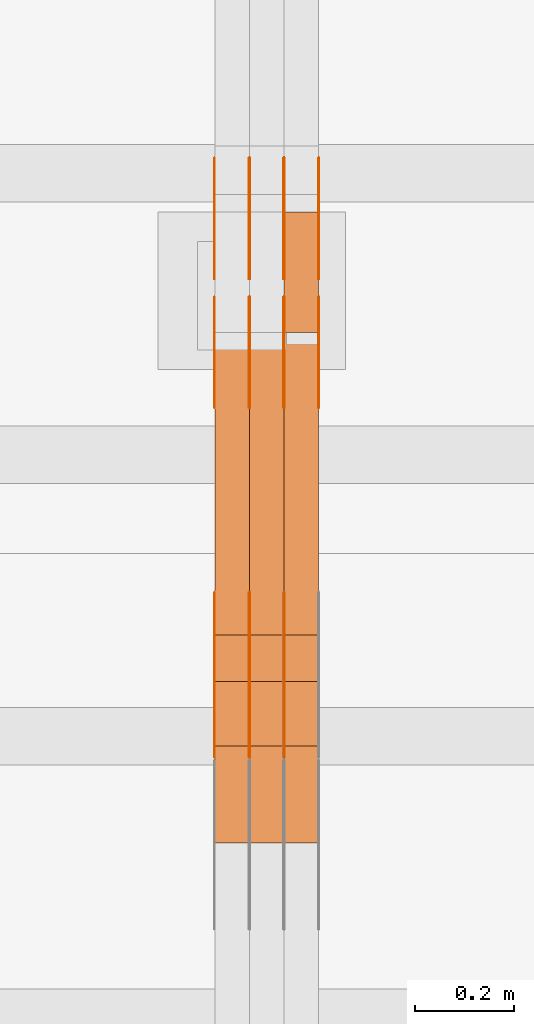
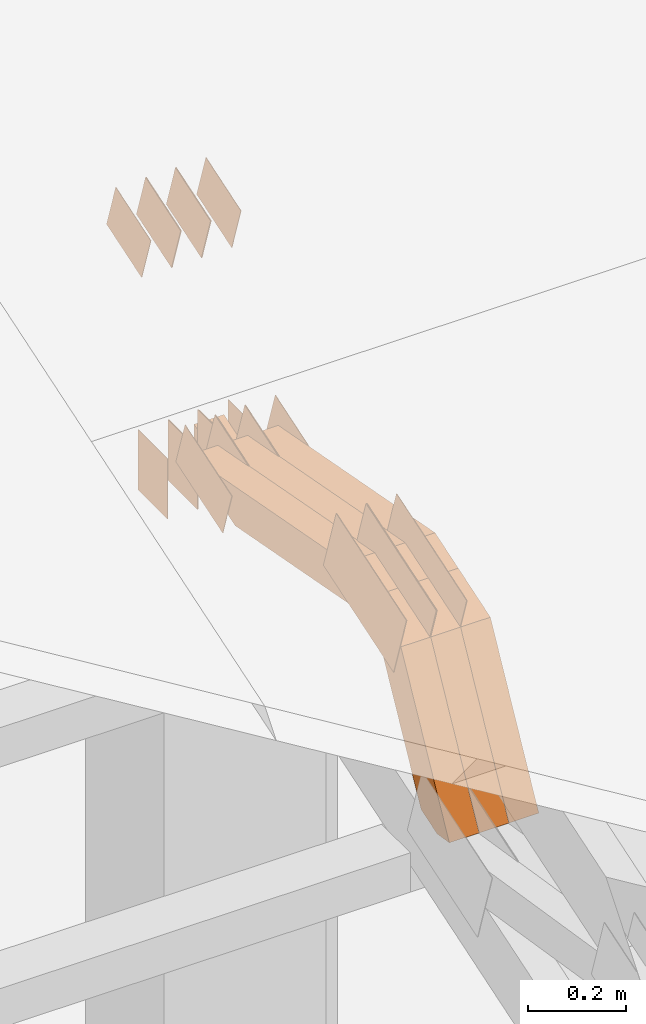
# One storey, part 280 of 385: 29 proxies.
"""IFC2X3 building model written with IfcOpenShell, lengths in millimetres."""

from ifc_helpers import new_model, entity, si_unit, converted_unit, derived_unit, direction, frame, frame_2d, origin, place, context, subcontext, project, spatial, polyline, rectangle, outline, extrude, source, transform, mapped, material, type_object, type_shapes, element, save


model = new_model("IFC2X3")

# Units and contexts
model_context = context("Model", 3, precision=0.01, world=origin(), true_north=direction((6.12303176911189e-17, 1.0)))
body_context = subcontext(model_context, "Body", "Model", "MODEL_VIEW")
ifc_project = project(units=[si_unit("LENGTHUNIT", "METRE", prefix="MILLI"), si_unit("AREAUNIT", "SQUARE_METRE"), si_unit("VOLUMEUNIT", "CUBIC_METRE"), converted_unit("PLANEANGLEUNIT", "DEGREE", entity("IfcRatioMeasure", 0.0174532925199433), si_unit("PLANEANGLEUNIT", "RADIAN"), dimensions=[0, 0, 0, 0, 0, 0, 0]), si_unit("MASSUNIT", "GRAM", prefix="KILO"), derived_unit("MASSDENSITYUNIT", [(si_unit("MASSUNIT", "GRAM", prefix="KILO"), 1), (si_unit("LENGTHUNIT", "METRE"), -3)]), si_unit("TIMEUNIT", "SECOND"), si_unit("FREQUENCYUNIT", "HERTZ"), si_unit("THERMODYNAMICTEMPERATUREUNIT", "DEGREE_CELSIUS"), derived_unit("THERMALTRANSMITTANCEUNIT", [(si_unit("MASSUNIT", "GRAM", prefix="KILO"), 1), (si_unit("THERMODYNAMICTEMPERATUREUNIT", "KELVIN"), -1), (si_unit("TIMEUNIT", "SECOND"), -3)]), derived_unit("VOLUMETRICFLOWRATEUNIT", [(si_unit("LENGTHUNIT", "METRE"), 3), (si_unit("TIMEUNIT", "SECOND"), -1)]), si_unit("ELECTRICCURRENTUNIT", "AMPERE"), si_unit("ELECTRICVOLTAGEUNIT", "VOLT"), si_unit("POWERUNIT", "WATT"), si_unit("FORCEUNIT", "NEWTON", prefix="KILO"), si_unit("ILLUMINANCEUNIT", "LUX"), si_unit("LUMINOUSFLUXUNIT", "LUMEN"), si_unit("LUMINOUSINTENSITYUNIT", "CANDELA"), derived_unit("USERDEFINED", [(si_unit("MASSUNIT", "GRAM", prefix="KILO"), -1), (si_unit("LENGTHUNIT", "METRE"), -2), (si_unit("TIMEUNIT", "SECOND"), 3), (si_unit("LUMINOUSFLUXUNIT", "LUMEN"), 1)]), derived_unit("LINEARVELOCITYUNIT", [(si_unit("LENGTHUNIT", "METRE"), 1), (si_unit("TIMEUNIT", "SECOND"), -1)]), si_unit("PRESSUREUNIT", "PASCAL"), derived_unit("USERDEFINED", [(si_unit("LENGTHUNIT", "METRE"), -2), (si_unit("MASSUNIT", "GRAM", prefix="KILO"), 1), (si_unit("TIMEUNIT", "SECOND"), -2)])], contexts=[model_context])

# Site, building, storey
site_placement = place(None, origin())
site = spatial("IfcSite", under=ifc_project, at=site_placement, CompositionType="ELEMENT")
building_placement = place(site_placement, origin())
building = spatial("IfcBuilding", under=site, at=building_placement, CompositionType="ELEMENT")
storey_placement = place(building_placement, origin())
storey = spatial("IfcBuildingStorey", under=building, at=storey_placement, Name="Default", CompositionType="ELEMENT", Elevation=0.0)

# Proxies
ifc_material_1 = material(Name="IfcSurfaceStyle #448112")
building_element_proxy_type_1 = type_object("IfcBuildingElementProxyType", PredefinedType="NOTDEFINED", material=ifc_material_1)
shared_shape_1 = source(origin(), body_context, "Body", "SweptSolid", [
    extrude(outline(polyline([(-99.9997874178038, -60.0000528641967), (99.9998102700997, -60.0000528641967), (99.9998251396068, 60.0000528641967), (-99.9998479919027, 60.0000528641967), (-99.9997874178038, -60.0000528641967)])), frame((99.9999918898597, 60.0000528641967, 0.0), z_axis=(0.0, 0.0, 1.0), x_axis=(-1.0, 0.0, 0.0)), (0.0, 0.0, 1.0), 1.3),
])
type_shapes(building_element_proxy_type_1, [shared_shape_1])
proxy_1_placement = place(building_placement, frame((36386.3, 11991.9568177725, 3072.52282247925), z_axis=(-1.0, 0.0, 0.0), x_axis=(0.0, 0.951056516295124, 0.309016994375039)))
element("IfcBuildingElementProxy", 1, at=proxy_1_placement, inside=storey, type_object=building_element_proxy_type_1, material=ifc_material_1, context=body_context, shape_type="MappedRepresentation", body=[
    mapped(shared_shape_1, transform((0.0, 0.0, 0.0), scale=1.0)),
])
ifc_material_2 = material(Name="IfcSurfaceStyle #448055")
building_element_proxy_type_2 = type_object("IfcBuildingElementProxyType", PredefinedType="NOTDEFINED", material=ifc_material_2)
shared_shape_2 = source(origin(), body_context, "Body", "SweptSolid", [
    extrude(outline(polyline([(-99.9997874178038, -60.0000528641967), (99.9998102700997, -60.0000528641967), (99.9998251396068, 60.0000528641967), (-99.9998479919027, 60.0000528641967), (-99.9997874178038, -60.0000528641967)])), frame((99.9999918898597, 60.0000528641967, 0.0), z_axis=(0.0, 0.0, 1.0), x_axis=(-1.0, 0.0, 0.0)), (0.0, 0.0, 1.0), 1.3),
])
type_shapes(building_element_proxy_type_2, [shared_shape_2])
proxy_2_placement = place(building_placement, frame((36315.0, 11991.9568177725, 3072.52282247925), z_axis=(-1.0, 0.0, 0.0), x_axis=(0.0, 0.951056516295124, 0.309016994375039)))
element("IfcBuildingElementProxy", 2, at=proxy_2_placement, inside=storey, type_object=building_element_proxy_type_2, material=ifc_material_2, context=body_context, shape_type="MappedRepresentation", body=[
    mapped(shared_shape_2, transform((0.0, 0.0, 0.0), scale=1.0)),
])
ifc_material_3 = material(Name="IfcSurfaceStyle #447998")
building_element_proxy_type_3 = type_object("IfcBuildingElementProxyType", PredefinedType="NOTDEFINED", material=ifc_material_3)
shared_shape_3 = source(origin(), body_context, "Body", "SweptSolid", [
    extrude(outline(polyline([(-99.9997874178038, -60.0000528641967), (99.9998102700997, -60.0000528641967), (99.9998251396068, 60.0000528641967), (-99.9998479919027, 60.0000528641967), (-99.9997874178038, -60.0000528641967)])), frame((99.9999918898597, 60.0000528641967, 0.0), z_axis=(0.0, 0.0, 1.0), x_axis=(-1.0, 0.0, 0.0)), (0.0, 0.0, 1.0), 1.3),
])
type_shapes(building_element_proxy_type_3, [shared_shape_3])
proxy_3_placement = place(building_placement, frame((36316.3, 11991.9568177725, 3072.52282247925), z_axis=(-1.0, 0.0, 0.0), x_axis=(0.0, 0.951056516295124, 0.309016994375039)))
element("IfcBuildingElementProxy", 3, at=proxy_3_placement, inside=storey, type_object=building_element_proxy_type_3, material=ifc_material_3, context=body_context, shape_type="MappedRepresentation", body=[
    mapped(shared_shape_3, transform((0.0, 0.0, 0.0), scale=1.0)),
])
ifc_material_4 = material(Name="IfcSurfaceStyle #447941")
building_element_proxy_type_4 = type_object("IfcBuildingElementProxyType", PredefinedType="NOTDEFINED", material=ifc_material_4)
shared_shape_4 = source(origin(), body_context, "Body", "SweptSolid", [
    extrude(outline(polyline([(-99.9997874178038, -60.0000528641967), (99.9998102700997, -60.0000528641967), (99.9998251396068, 60.0000528641967), (-99.9998479919027, 60.0000528641967), (-99.9997874178038, -60.0000528641967)])), frame((99.9999918898597, 60.0000528641967, 0.0), z_axis=(0.0, 0.0, 1.0), x_axis=(-1.0, 0.0, 0.0)), (0.0, 0.0, 1.0), 1.29999999999998),
])
type_shapes(building_element_proxy_type_4, [shared_shape_4])
proxy_4_placement = place(building_placement, frame((36245.0, 11991.9568177725, 3072.52282247925), z_axis=(-1.0, 0.0, 0.0), x_axis=(0.0, 0.951056516295124, 0.309016994375039)))
element("IfcBuildingElementProxy", 4, at=proxy_4_placement, inside=storey, type_object=building_element_proxy_type_4, material=ifc_material_4, context=body_context, shape_type="MappedRepresentation", body=[
    mapped(shared_shape_4, transform((0.0, 0.0, 0.0), scale=1.0)),
])
ifc_material_5 = material(Name="IfcSurfaceStyle #447884")
building_element_proxy_type_5 = type_object("IfcBuildingElementProxyType", PredefinedType="NOTDEFINED", material=ifc_material_5)
shared_shape_5 = source(origin(), body_context, "Body", "SweptSolid", [
    extrude(outline(polyline([(-99.9997874178038, -60.0000528641967), (99.9998102700997, -60.0000528641967), (99.9998251396068, 60.0000528641967), (-99.9998479919027, 60.0000528641967), (-99.9997874178038, -60.0000528641967)])), frame((99.9999918898597, 60.0000528641967, 0.0), z_axis=(0.0, 0.0, 1.0), x_axis=(-1.0, 0.0, 0.0)), (0.0, 0.0, 1.0), 1.29999999999998),
])
type_shapes(building_element_proxy_type_5, [shared_shape_5])
proxy_5_placement = place(building_placement, frame((36246.3, 11991.9568177725, 3072.52282247925), z_axis=(-1.0, 0.0, 0.0), x_axis=(0.0, 0.951056516295124, 0.309016994375039)))
element("IfcBuildingElementProxy", 5, at=proxy_5_placement, inside=storey, type_object=building_element_proxy_type_5, material=ifc_material_5, context=body_context, shape_type="MappedRepresentation", body=[
    mapped(shared_shape_5, transform((0.0, 0.0, 0.0), scale=1.0)),
])
ifc_material_6 = material(Name="IfcSurfaceStyle #447827")
building_element_proxy_type_6 = type_object("IfcBuildingElementProxyType", PredefinedType="NOTDEFINED", material=ifc_material_6)
shared_shape_6 = source(origin(), body_context, "Body", "SweptSolid", [
    extrude(outline(polyline([(-99.9997874178038, -60.0000528641967), (99.9998102700997, -60.0000528641967), (99.9998251396068, 60.0000528641967), (-99.9998479919027, 60.0000528641967), (-99.9997874178038, -60.0000528641967)])), frame((99.9999918898597, 60.0000528641967, 0.0), z_axis=(0.0, 0.0, 1.0), x_axis=(-1.0, 0.0, 0.0)), (0.0, 0.0, 1.0), 1.29999999999999),
])
type_shapes(building_element_proxy_type_6, [shared_shape_6])
proxy_6_placement = place(building_placement, frame((36175.0, 11991.9568177725, 3072.52282247925), z_axis=(-1.0, 0.0, 0.0), x_axis=(0.0, 0.951056516295124, 0.309016994375039)))
element("IfcBuildingElementProxy", 6, at=proxy_6_placement, inside=storey, type_object=building_element_proxy_type_6, material=ifc_material_6, context=body_context, shape_type="MappedRepresentation", body=[
    mapped(shared_shape_6, transform((0.0, 0.0, 0.0), scale=1.0)),
])
ifc_material_7 = material(Name="IfcSurfaceStyle #447770")
building_element_proxy_type_7 = type_object("IfcBuildingElementProxyType", PredefinedType="NOTDEFINED", material=ifc_material_7)
shared_shape_7 = source(origin(), body_context, "Body", "SweptSolid", [
    extrude(rectangle(XDim=150.0, YDim=119.999999999985, at=frame_2d((-7.105427357601e-15, 0.0), x_axis=(1.0, 0.0))), frame((75.0, 60.0, 0.0), z_axis=(0.0, 0.0, 1.0), x_axis=(-1.0, 0.0, 0.0)), (0.0, 0.0, 1.0), 1.3),
])
type_shapes(building_element_proxy_type_7, [shared_shape_7])
proxy_7_placement = place(building_placement, frame((36386.3, 12372.95703125, 3007.04687500001), z_axis=(-1.0, 0.0, 0.0), x_axis=(0.0, 0.0, -1.0)))
element("IfcBuildingElementProxy", 7, at=proxy_7_placement, inside=storey, type_object=building_element_proxy_type_7, material=ifc_material_7, context=body_context, shape_type="MappedRepresentation", body=[
    mapped(shared_shape_7, transform((0.0, 0.0, 0.0), scale=1.0)),
])
ifc_material_8 = material(Name="IfcSurfaceStyle #447713")
building_element_proxy_type_8 = type_object("IfcBuildingElementProxyType", PredefinedType="NOTDEFINED", material=ifc_material_8)
shared_shape_8 = source(origin(), body_context, "Body", "SweptSolid", [
    extrude(rectangle(XDim=150.0, YDim=119.999999999985, at=frame_2d((-7.105427357601e-15, 0.0), x_axis=(1.0, 0.0))), frame((75.0, 60.0, 0.0), z_axis=(0.0, 0.0, 1.0), x_axis=(-1.0, 0.0, 0.0)), (0.0, 0.0, 1.0), 1.3),
])
type_shapes(building_element_proxy_type_8, [shared_shape_8])
proxy_8_placement = place(building_placement, frame((36315.0, 12372.95703125, 3007.04687500001), z_axis=(-1.0, 0.0, 0.0), x_axis=(0.0, 0.0, -1.0)))
element("IfcBuildingElementProxy", 8, at=proxy_8_placement, inside=storey, type_object=building_element_proxy_type_8, material=ifc_material_8, context=body_context, shape_type="MappedRepresentation", body=[
    mapped(shared_shape_8, transform((0.0, 0.0, 0.0), scale=1.0)),
])
ifc_material_9 = material(Name="IfcSurfaceStyle #447656")
building_element_proxy_type_9 = type_object("IfcBuildingElementProxyType", PredefinedType="NOTDEFINED", material=ifc_material_9)
shared_shape_9 = source(origin(), body_context, "Body", "SweptSolid", [
    extrude(rectangle(XDim=150.0, YDim=119.999999999985, at=frame_2d((-7.105427357601e-15, 0.0), x_axis=(1.0, 0.0))), frame((75.0, 60.0, 0.0), z_axis=(0.0, 0.0, 1.0), x_axis=(-1.0, 0.0, 0.0)), (0.0, 0.0, 1.0), 1.3),
])
type_shapes(building_element_proxy_type_9, [shared_shape_9])
proxy_9_placement = place(building_placement, frame((36316.3, 12372.95703125, 3007.04687500001), z_axis=(-1.0, 0.0, 0.0), x_axis=(0.0, 0.0, -1.0)))
element("IfcBuildingElementProxy", 9, at=proxy_9_placement, inside=storey, type_object=building_element_proxy_type_9, material=ifc_material_9, context=body_context, shape_type="MappedRepresentation", body=[
    mapped(shared_shape_9, transform((0.0, 0.0, 0.0), scale=1.0)),
])
ifc_material_10 = material(Name="IfcSurfaceStyle #447599")
building_element_proxy_type_10 = type_object("IfcBuildingElementProxyType", PredefinedType="NOTDEFINED", material=ifc_material_10)
shared_shape_10 = source(origin(), body_context, "Body", "SweptSolid", [
    extrude(rectangle(XDim=150.0, YDim=119.999999999985, at=frame_2d((-7.105427357601e-15, 0.0), x_axis=(1.0, 0.0))), frame((75.0, 60.0, 0.0), z_axis=(0.0, 0.0, 1.0), x_axis=(-1.0, 0.0, 0.0)), (0.0, 0.0, 1.0), 1.29999999999999),
])
type_shapes(building_element_proxy_type_10, [shared_shape_10])
proxy_10_placement = place(building_placement, frame((36245.0, 12372.95703125, 3007.04687500001), z_axis=(-1.0, 0.0, 0.0), x_axis=(0.0, 0.0, -1.0)))
element("IfcBuildingElementProxy", 10, at=proxy_10_placement, inside=storey, type_object=building_element_proxy_type_10, material=ifc_material_10, context=body_context, shape_type="MappedRepresentation", body=[
    mapped(shared_shape_10, transform((0.0, 0.0, 0.0), scale=1.0)),
])
ifc_material_11 = material(Name="IfcSurfaceStyle #447542")
building_element_proxy_type_11 = type_object("IfcBuildingElementProxyType", PredefinedType="NOTDEFINED", material=ifc_material_11)
shared_shape_11 = source(origin(), body_context, "Body", "SweptSolid", [
    extrude(rectangle(XDim=150.0, YDim=119.999999999985, at=frame_2d((-7.105427357601e-15, 0.0), x_axis=(1.0, 0.0))), frame((75.0, 60.0, 0.0), z_axis=(0.0, 0.0, 1.0), x_axis=(-1.0, 0.0, 0.0)), (0.0, 0.0, 1.0), 1.29999999999999),
])
type_shapes(building_element_proxy_type_11, [shared_shape_11])
proxy_11_placement = place(building_placement, frame((36246.3, 12372.95703125, 3007.04687500001), z_axis=(-1.0, 0.0, 0.0), x_axis=(0.0, 0.0, -1.0)))
element("IfcBuildingElementProxy", 11, at=proxy_11_placement, inside=storey, type_object=building_element_proxy_type_11, material=ifc_material_11, context=body_context, shape_type="MappedRepresentation", body=[
    mapped(shared_shape_11, transform((0.0, 0.0, 0.0), scale=1.0)),
])
ifc_material_12 = material(Name="IfcSurfaceStyle #447485")
building_element_proxy_type_12 = type_object("IfcBuildingElementProxyType", PredefinedType="NOTDEFINED", material=ifc_material_12)
shared_shape_12 = source(origin(), body_context, "Body", "SweptSolid", [
    extrude(rectangle(XDim=150.0, YDim=119.999999999985, at=frame_2d((-7.105427357601e-15, 0.0), x_axis=(1.0, 0.0))), frame((75.0, 60.0, 0.0), z_axis=(0.0, 0.0, 1.0), x_axis=(-1.0, 0.0, 0.0)), (0.0, 0.0, 1.0), 1.29999999999999),
])
type_shapes(building_element_proxy_type_12, [shared_shape_12])
proxy_12_placement = place(building_placement, frame((36175.0, 12372.95703125, 3007.04687500001), z_axis=(-1.0, 0.0, 0.0), x_axis=(0.0, 0.0, -1.0)))
element("IfcBuildingElementProxy", 12, at=proxy_12_placement, inside=storey, type_object=building_element_proxy_type_12, material=ifc_material_12, context=body_context, shape_type="MappedRepresentation", body=[
    mapped(shared_shape_12, transform((0.0, 0.0, 0.0), scale=1.0)),
])
ifc_material_13 = material(Name="IfcSurfaceStyle #440588")
building_element_proxy_type_13 = type_object("IfcBuildingElementProxyType", PredefinedType="NOTDEFINED", material=ifc_material_13)
shared_shape_13 = source(origin(), body_context, "Body", "SweptSolid", [
    extrude(outline(polyline([(-74.9998754286244, -60.0000016373506), (74.9998605591063, -60.0000016373506), (74.9998754286244, 60.0000016373506), (-74.9998605591063, 60.0000016373506), (-74.9998754286244, -60.0000016373506)])), frame((74.9998754286244, 60.0000016373506, 0.0), z_axis=(0.0, 0.0, 1.0), x_axis=(-1.0, 0.0, 0.0)), (0.0, 0.0, 1.0), 1.3),
])
type_shapes(building_element_proxy_type_13, [shared_shape_13])
proxy_13_placement = place(building_placement, frame((36386.3, 12321.1620861463, 3506.17707344366), z_axis=(-1.0, 0.0, 0.0), x_axis=(0.0, 0.951056516295154, 0.309016994374948)))
element("IfcBuildingElementProxy", 13, at=proxy_13_placement, inside=storey, type_object=building_element_proxy_type_13, material=ifc_material_13, context=body_context, shape_type="MappedRepresentation", body=[
    mapped(shared_shape_13, transform((0.0, 0.0, 0.0), scale=1.0)),
])
ifc_material_14 = material(Name="IfcSurfaceStyle #440531")
building_element_proxy_type_14 = type_object("IfcBuildingElementProxyType", PredefinedType="NOTDEFINED", material=ifc_material_14)
shared_shape_14 = source(origin(), body_context, "Body", "SweptSolid", [
    extrude(outline(polyline([(-74.9998754286244, -60.0000016373506), (74.9998605591063, -60.0000016373506), (74.9998754286244, 60.0000016373506), (-74.9998605591063, 60.0000016373506), (-74.9998754286244, -60.0000016373506)])), frame((74.9998754286244, 60.0000016373506, 0.0), z_axis=(0.0, 0.0, 1.0), x_axis=(-1.0, 0.0, 0.0)), (0.0, 0.0, 1.0), 1.3),
])
type_shapes(building_element_proxy_type_14, [shared_shape_14])
proxy_14_placement = place(building_placement, frame((36315.0, 12321.1620861463, 3506.17707344366), z_axis=(-1.0, 0.0, 0.0), x_axis=(0.0, 0.951056516295154, 0.309016994374948)))
element("IfcBuildingElementProxy", 14, at=proxy_14_placement, inside=storey, type_object=building_element_proxy_type_14, material=ifc_material_14, context=body_context, shape_type="MappedRepresentation", body=[
    mapped(shared_shape_14, transform((0.0, 0.0, 0.0), scale=1.0)),
])
ifc_material_15 = material(Name="IfcSurfaceStyle #440474")
building_element_proxy_type_15 = type_object("IfcBuildingElementProxyType", PredefinedType="NOTDEFINED", material=ifc_material_15)
shared_shape_15 = source(origin(), body_context, "Body", "SweptSolid", [
    extrude(outline(polyline([(-74.9998754286244, -60.0000016373506), (74.9998605591063, -60.0000016373506), (74.9998754286244, 60.0000016373506), (-74.9998605591063, 60.0000016373506), (-74.9998754286244, -60.0000016373506)])), frame((74.9998754286244, 60.0000016373506, 0.0), z_axis=(0.0, 0.0, 1.0), x_axis=(-1.0, 0.0, 0.0)), (0.0, 0.0, 1.0), 1.3),
])
type_shapes(building_element_proxy_type_15, [shared_shape_15])
proxy_15_placement = place(building_placement, frame((36316.3, 12321.1620861463, 3506.17707344366), z_axis=(-1.0, 0.0, 0.0), x_axis=(0.0, 0.951056516295154, 0.309016994374948)))
element("IfcBuildingElementProxy", 15, at=proxy_15_placement, inside=storey, type_object=building_element_proxy_type_15, material=ifc_material_15, context=body_context, shape_type="MappedRepresentation", body=[
    mapped(shared_shape_15, transform((0.0, 0.0, 0.0), scale=1.0)),
])
ifc_material_16 = material(Name="IfcSurfaceStyle #440417")
building_element_proxy_type_16 = type_object("IfcBuildingElementProxyType", PredefinedType="NOTDEFINED", material=ifc_material_16)
shared_shape_16 = source(origin(), body_context, "Body", "SweptSolid", [
    extrude(outline(polyline([(-74.9998754286244, -60.0000016373506), (74.9998605591063, -60.0000016373506), (74.9998754286244, 60.0000016373506), (-74.9998605591063, 60.0000016373506), (-74.9998754286244, -60.0000016373506)])), frame((74.9998754286244, 60.0000016373506, 0.0), z_axis=(0.0, 0.0, 1.0), x_axis=(-1.0, 0.0, 0.0)), (0.0, 0.0, 1.0), 1.29999999999999),
])
type_shapes(building_element_proxy_type_16, [shared_shape_16])
proxy_16_placement = place(building_placement, frame((36245.0, 12321.1620861463, 3506.17707344366), z_axis=(-1.0, 0.0, 0.0), x_axis=(0.0, 0.951056516295154, 0.309016994374948)))
element("IfcBuildingElementProxy", 16, at=proxy_16_placement, inside=storey, type_object=building_element_proxy_type_16, material=ifc_material_16, context=body_context, shape_type="MappedRepresentation", body=[
    mapped(shared_shape_16, transform((0.0, 0.0, 0.0), scale=1.0)),
])
ifc_material_17 = material(Name="IfcSurfaceStyle #440360")
building_element_proxy_type_17 = type_object("IfcBuildingElementProxyType", PredefinedType="NOTDEFINED", material=ifc_material_17)
shared_shape_17 = source(origin(), body_context, "Body", "SweptSolid", [
    extrude(outline(polyline([(-74.9998754286244, -60.0000016373506), (74.9998605591063, -60.0000016373506), (74.9998754286244, 60.0000016373506), (-74.9998605591063, 60.0000016373506), (-74.9998754286244, -60.0000016373506)])), frame((74.9998754286244, 60.0000016373506, 0.0), z_axis=(0.0, 0.0, 1.0), x_axis=(-1.0, 0.0, 0.0)), (0.0, 0.0, 1.0), 1.29999999999999),
])
type_shapes(building_element_proxy_type_17, [shared_shape_17])
proxy_17_placement = place(building_placement, frame((36246.3, 12321.1620861463, 3506.17707344366), z_axis=(-1.0, 0.0, 0.0), x_axis=(0.0, 0.951056516295154, 0.309016994374948)))
element("IfcBuildingElementProxy", 17, at=proxy_17_placement, inside=storey, type_object=building_element_proxy_type_17, material=ifc_material_17, context=body_context, shape_type="MappedRepresentation", body=[
    mapped(shared_shape_17, transform((0.0, 0.0, 0.0), scale=1.0)),
])
ifc_material_18 = material(Name="IfcSurfaceStyle #440303")
building_element_proxy_type_18 = type_object("IfcBuildingElementProxyType", PredefinedType="NOTDEFINED", material=ifc_material_18)
shared_shape_18 = source(origin(), body_context, "Body", "SweptSolid", [
    extrude(outline(polyline([(-74.9998754286244, -60.0000016373506), (74.9998605591063, -60.0000016373506), (74.9998754286244, 60.0000016373506), (-74.9998605591063, 60.0000016373506), (-74.9998754286244, -60.0000016373506)])), frame((74.9998754286244, 60.0000016373506, 0.0), z_axis=(0.0, 0.0, 1.0), x_axis=(-1.0, 0.0, 0.0)), (0.0, 0.0, 1.0), 1.29999999999999),
])
type_shapes(building_element_proxy_type_18, [shared_shape_18])
proxy_18_placement = place(building_placement, frame((36175.0, 12321.1620861463, 3506.17707344366), z_axis=(-1.0, 0.0, 0.0), x_axis=(0.0, 0.951056516295154, 0.309016994374948)))
element("IfcBuildingElementProxy", 18, at=proxy_18_placement, inside=storey, type_object=building_element_proxy_type_18, material=ifc_material_18, context=body_context, shape_type="MappedRepresentation", body=[
    mapped(shared_shape_18, transform((0.0, 0.0, 0.0), scale=1.0)),
])
ifc_material_19 = material(Name="IfcSurfaceStyle #439790")
building_element_proxy_type_19 = type_object("IfcBuildingElementProxyType", PredefinedType="NOTDEFINED", material=ifc_material_19)
shared_shape_19 = source(origin(), body_context, "Body", "SweptSolid", [
    extrude(outline(polyline([(-150.000273478628, -84.0002987844282), (149.999198496832, -84.0002987844282), (150.000273478627, 84.0002987844282), (-149.999198496831, 84.0002987844282), (-150.000273478628, -84.0002987844282)])), frame((150.000273478627, 84.0002987844282, 0.0), z_axis=(0.0, 0.0, 1.0), x_axis=(-1.0, 0.0, 0.0)), (0.0, 0.0, 1.0), 1.29999999999999),
])
type_shapes(building_element_proxy_type_19, [shared_shape_19])
proxy_19_placement = place(building_placement, frame((36316.3, 11283.0116722926, 3194.09682266857), z_axis=(-1.0, 0.0, 0.0), x_axis=(0.0, 0.951056516295154, 0.309016994374948)))
element("IfcBuildingElementProxy", 19, at=proxy_19_placement, inside=storey, type_object=building_element_proxy_type_19, material=ifc_material_19, context=body_context, shape_type="MappedRepresentation", body=[
    mapped(shared_shape_19, transform((0.0, 0.0, 0.0), scale=1.0)),
])
ifc_material_20 = material(Name="IfcSurfaceStyle #439733")
building_element_proxy_type_20 = type_object("IfcBuildingElementProxyType", PredefinedType="NOTDEFINED", material=ifc_material_20)
shared_shape_20 = source(origin(), body_context, "Body", "SweptSolid", [
    extrude(outline(polyline([(-150.000273478628, -84.0002987844282), (149.999198496832, -84.0002987844282), (150.000273478627, 84.0002987844282), (-149.999198496831, 84.0002987844282), (-150.000273478628, -84.0002987844282)])), frame((150.000273478627, 84.0002987844282, 0.0), z_axis=(0.0, 0.0, 1.0), x_axis=(-1.0, 0.0, 0.0)), (0.0, 0.0, 1.0), 1.29999999999998),
])
type_shapes(building_element_proxy_type_20, [shared_shape_20])
proxy_20_placement = place(building_placement, frame((36245.0, 11283.0116722926, 3194.09682266857), z_axis=(-1.0, 0.0, 0.0), x_axis=(0.0, 0.951056516295154, 0.309016994374948)))
element("IfcBuildingElementProxy", 20, at=proxy_20_placement, inside=storey, type_object=building_element_proxy_type_20, material=ifc_material_20, context=body_context, shape_type="MappedRepresentation", body=[
    mapped(shared_shape_20, transform((0.0, 0.0, 0.0), scale=1.0)),
])
ifc_material_21 = material(Name="IfcSurfaceStyle #439676")
building_element_proxy_type_21 = type_object("IfcBuildingElementProxyType", PredefinedType="NOTDEFINED", material=ifc_material_21)
shared_shape_21 = source(origin(), body_context, "Body", "SweptSolid", [
    extrude(outline(polyline([(-150.000273478628, -84.0002987844282), (149.999198496832, -84.0002987844282), (150.000273478627, 84.0002987844282), (-149.999198496831, 84.0002987844282), (-150.000273478628, -84.0002987844282)])), frame((150.000273478627, 84.0002987844282, 0.0), z_axis=(0.0, 0.0, 1.0), x_axis=(-1.0, 0.0, 0.0)), (0.0, 0.0, 1.0), 1.29999999999998),
])
type_shapes(building_element_proxy_type_21, [shared_shape_21])
proxy_21_placement = place(building_placement, frame((36246.3, 11283.0116722926, 3194.09682266857), z_axis=(-1.0, 0.0, 0.0), x_axis=(0.0, 0.951056516295154, 0.309016994374948)))
element("IfcBuildingElementProxy", 21, at=proxy_21_placement, inside=storey, type_object=building_element_proxy_type_21, material=ifc_material_21, context=body_context, shape_type="MappedRepresentation", body=[
    mapped(shared_shape_21, transform((0.0, 0.0, 0.0), scale=1.0)),
])
ifc_material_22 = material(Name="IfcSurfaceStyle #439619")
building_element_proxy_type_22 = type_object("IfcBuildingElementProxyType", PredefinedType="NOTDEFINED", material=ifc_material_22)
shared_shape_22 = source(origin(), body_context, "Body", "SweptSolid", [
    extrude(outline(polyline([(-150.000273478628, -84.0002987844282), (149.999198496832, -84.0002987844282), (150.000273478627, 84.0002987844282), (-149.999198496831, 84.0002987844282), (-150.000273478628, -84.0002987844282)])), frame((150.000273478627, 84.0002987844282, 0.0), z_axis=(0.0, 0.0, 1.0), x_axis=(-1.0, 0.0, 0.0)), (0.0, 0.0, 1.0), 1.29999999999998),
])
type_shapes(building_element_proxy_type_22, [shared_shape_22])
proxy_22_placement = place(building_placement, frame((36175.0, 11283.0116722926, 3194.09682266857), z_axis=(-1.0, 0.0, 0.0), x_axis=(0.0, 0.951056516295154, 0.309016994374948)))
element("IfcBuildingElementProxy", 22, at=proxy_22_placement, inside=storey, type_object=building_element_proxy_type_22, material=ifc_material_22, context=body_context, shape_type="MappedRepresentation", body=[
    mapped(shared_shape_22, transform((0.0, 0.0, 0.0), scale=1.0)),
])
ifc_material_23 = material(Name="IfcSurfaceStyle #432128")
building_element_proxy_type_23 = type_object("IfcBuildingElementProxyType", Name="T1-E1 432126", PredefinedType="NOTDEFINED", material=ifc_material_23)
shared_shape_23 = source(origin(), body_context, "Body", "SweptSolid", [
    extrude(outline(polyline([(-75.1378173828004, -122.500000000005), (35.3350830078246, -122.500000000005), (35.3350830078004, 122.500000000005), (4.46765136717545, 122.500000000005), (-75.1378173828004, -122.500000000005)])), frame((35.3350830078246, 122.500000104877, 0.0), z_axis=(0.0, 0.0, 1.0), x_axis=(-1.0, 0.0, 0.0)), (0.0, 0.0, 1.0), 70.0),
])
type_shapes(building_element_proxy_type_23, [shared_shape_23])
proxy_23_placement = place(building_placement, frame((36385.0, 12145.0, 2849.54565429685), z_axis=(-1.0, 0.0, 0.0), x_axis=(0.0, 0.0, 1.0)))
element("IfcBuildingElementProxy", 23, at=proxy_23_placement, inside=storey, type_object=building_element_proxy_type_23, material=ifc_material_23, Name="T1-E1", context=body_context, shape_type="MappedRepresentation", body=[
    mapped(shared_shape_23, transform((0.0, 0.0, 0.0), scale=1.0)),
])
ifc_material_24 = material(Name="IfcSurfaceStyle #429608")
building_element_proxy_type_24 = type_object("IfcBuildingElementProxyType", Name="T1-W9 429606", PredefinedType="NOTDEFINED", material=ifc_material_24)
shared_shape_24 = source(origin(), body_context, "Body", "SweptSolid", [
    extrude(outline(polyline([(-287.457507623288, -47.5000268597988), (288.590479960635, -47.5000268597988), (273.55062971372, -2.33146189358546e-05), (186.625054999886, 47.5000385171083), (-461.308657050953, 47.5000385171083), (-287.457507623288, -47.5000268597988)])), frame((288.590945855618, 47.5000968036551, 0.0), z_axis=(0.0, 0.0, 1.0), x_axis=(-1.0, 0.0, 0.0)), (0.0, 0.0, 1.0), 70.0),
])
type_shapes(building_element_proxy_type_24, [shared_shape_24])
proxy_24_placement = place(building_placement, frame((36385.0, 11432.1200855376, 3205.63308612017), z_axis=(-1.0, 0.0, 0.0), x_axis=(0.0, 0.982760503514031, -0.184883186722992)))
element("IfcBuildingElementProxy", 24, at=proxy_24_placement, inside=storey, type_object=building_element_proxy_type_24, material=ifc_material_24, Name="T1-W9", context=body_context, shape_type="MappedRepresentation", body=[
    mapped(shared_shape_24, transform((0.0, 0.0, 0.0), scale=1.0)),
])
ifc_material_25 = material(Name="IfcSurfaceStyle #429542")
building_element_proxy_type_25 = type_object("IfcBuildingElementProxyType", Name="T1-W9 429540", PredefinedType="NOTDEFINED", material=ifc_material_25)
shared_shape_25 = source(origin(), body_context, "Body", "SweptSolid", [
    extrude(outline(polyline([(-287.457507623288, -47.5000268597988), (288.590479960635, -47.5000268597988), (273.55062971372, -2.33146189358546e-05), (186.625054999886, 47.5000385171083), (-461.308657050953, 47.5000385171083), (-287.457507623288, -47.5000268597988)])), frame((288.590945855618, 47.5000968036551, 0.0), z_axis=(0.0, 0.0, 1.0), x_axis=(-1.0, 0.0, 0.0)), (0.0, 0.0, 1.0), 70.0),
])
type_shapes(building_element_proxy_type_25, [shared_shape_25])
proxy_25_placement = place(building_placement, frame((36315.0, 11432.1200855376, 3205.63308612017), z_axis=(-1.0, 0.0, 0.0), x_axis=(0.0, 0.982760503514031, -0.184883186722992)))
element("IfcBuildingElementProxy", 25, at=proxy_25_placement, inside=storey, type_object=building_element_proxy_type_25, material=ifc_material_25, Name="T1-W9", context=body_context, shape_type="MappedRepresentation", body=[
    mapped(shared_shape_25, transform((0.0, 0.0, 0.0), scale=1.0)),
])
ifc_material_26 = material(Name="IfcSurfaceStyle #429476")
building_element_proxy_type_26 = type_object("IfcBuildingElementProxyType", Name="T1-W9 429474", PredefinedType="NOTDEFINED", material=ifc_material_26)
shared_shape_26 = source(origin(), body_context, "Body", "SweptSolid", [
    extrude(outline(polyline([(-287.457507623288, -47.5000268597988), (288.590479960635, -47.5000268597988), (273.55062971372, -2.33146189358546e-05), (186.625054999886, 47.5000385171083), (-461.308657050953, 47.5000385171083), (-287.457507623288, -47.5000268597988)])), frame((288.590945855618, 47.5000968036551, 0.0), z_axis=(0.0, 0.0, 1.0), x_axis=(-1.0, 0.0, 0.0)), (0.0, 0.0, 1.0), 70.0),
])
type_shapes(building_element_proxy_type_26, [shared_shape_26])
proxy_26_placement = place(building_placement, frame((36245.0, 11432.1200855376, 3205.63308612017), z_axis=(-1.0, 0.0, 0.0), x_axis=(0.0, 0.982760503514031, -0.184883186722992)))
element("IfcBuildingElementProxy", 26, at=proxy_26_placement, inside=storey, type_object=building_element_proxy_type_26, material=ifc_material_26, Name="T1-W9", context=body_context, shape_type="MappedRepresentation", body=[
    mapped(shared_shape_26, transform((0.0, 0.0, 0.0), scale=1.0)),
])
ifc_material_27 = material(Name="IfcSurfaceStyle #429212")
building_element_proxy_type_27 = type_object("IfcBuildingElementProxyType", Name="T1-W32 429210", PredefinedType="NOTDEFINED", material=ifc_material_27)
shared_shape_27 = source(origin(), body_context, "Body", "SweptSolid", [
    extrude(outline(polyline([(-312.414547135921, -47.5000544873059), (136.677011757652, -47.5000544873059), (186.250996577889, 0.000369497452627243), (202.753116295831, 47.4998697385796), (-213.26657749545, 47.4998697385796), (-312.414547135921, -47.5000544873059)])), frame((202.753376481939, 47.5001296985553, 0.0), z_axis=(0.0, 0.0, 1.0), x_axis=(-1.0, 0.0, 0.0)), (0.0, 0.0, 1.0), 70.0),
])
type_shapes(building_element_proxy_type_27, [shared_shape_27])
proxy_27_placement = place(building_placement, frame((36385.0, 11110.7808979007, 2747.18129017315), z_axis=(-1.0, 0.0, 0.0), x_axis=(0.0, 0.472919689385906, 0.881105537033526)))
element("IfcBuildingElementProxy", 27, at=proxy_27_placement, inside=storey, type_object=building_element_proxy_type_27, material=ifc_material_27, Name="T1-W32", context=body_context, shape_type="MappedRepresentation", body=[
    mapped(shared_shape_27, transform((0.0, 0.0, 0.0), scale=1.0)),
])
ifc_material_28 = material(Name="IfcSurfaceStyle #429146")
building_element_proxy_type_28 = type_object("IfcBuildingElementProxyType", Name="T1-W32 429144", PredefinedType="NOTDEFINED", material=ifc_material_28)
shared_shape_28 = source(origin(), body_context, "Body", "SweptSolid", [
    extrude(outline(polyline([(-312.414547135921, -47.5000544873059), (136.677011757652, -47.5000544873059), (186.250996577889, 0.000369497452627243), (202.753116295831, 47.4998697385796), (-213.26657749545, 47.4998697385796), (-312.414547135921, -47.5000544873059)])), frame((202.753376481939, 47.5001296985553, 0.0), z_axis=(0.0, 0.0, 1.0), x_axis=(-1.0, 0.0, 0.0)), (0.0, 0.0, 1.0), 70.0),
])
type_shapes(building_element_proxy_type_28, [shared_shape_28])
proxy_28_placement = place(building_placement, frame((36315.0, 11110.7808979007, 2747.18129017315), z_axis=(-1.0, 0.0, 0.0), x_axis=(0.0, 0.472919689385906, 0.881105537033526)))
element("IfcBuildingElementProxy", 28, at=proxy_28_placement, inside=storey, type_object=building_element_proxy_type_28, material=ifc_material_28, Name="T1-W32", context=body_context, shape_type="MappedRepresentation", body=[
    mapped(shared_shape_28, transform((0.0, 0.0, 0.0), scale=1.0)),
])
ifc_material_29 = material(Name="IfcSurfaceStyle #429080")
building_element_proxy_type_29 = type_object("IfcBuildingElementProxyType", Name="T1-W32 429078", PredefinedType="NOTDEFINED", material=ifc_material_29)
shared_shape_29 = source(origin(), body_context, "Body", "SweptSolid", [
    extrude(outline(polyline([(-312.414547135921, -47.5000544873059), (136.677011757652, -47.5000544873059), (186.250996577889, 0.000369497452627243), (202.753116295831, 47.4998697385796), (-213.26657749545, 47.4998697385796), (-312.414547135921, -47.5000544873059)])), frame((202.753376481939, 47.5001296985553, 0.0), z_axis=(0.0, 0.0, 1.0), x_axis=(-1.0, 0.0, 0.0)), (0.0, 0.0, 1.0), 70.0),
])
type_shapes(building_element_proxy_type_29, [shared_shape_29])
proxy_29_placement = place(building_placement, frame((36245.0, 11110.7808979007, 2747.18129017315), z_axis=(-1.0, 0.0, 0.0), x_axis=(0.0, 0.472919689385906, 0.881105537033526)))
element("IfcBuildingElementProxy", 29, at=proxy_29_placement, inside=storey, type_object=building_element_proxy_type_29, material=ifc_material_29, Name="T1-W32", context=body_context, shape_type="MappedRepresentation", body=[
    mapped(shared_shape_29, transform((0.0, 0.0, 0.0), scale=1.0)),
])

save(model, "model.ifc")
